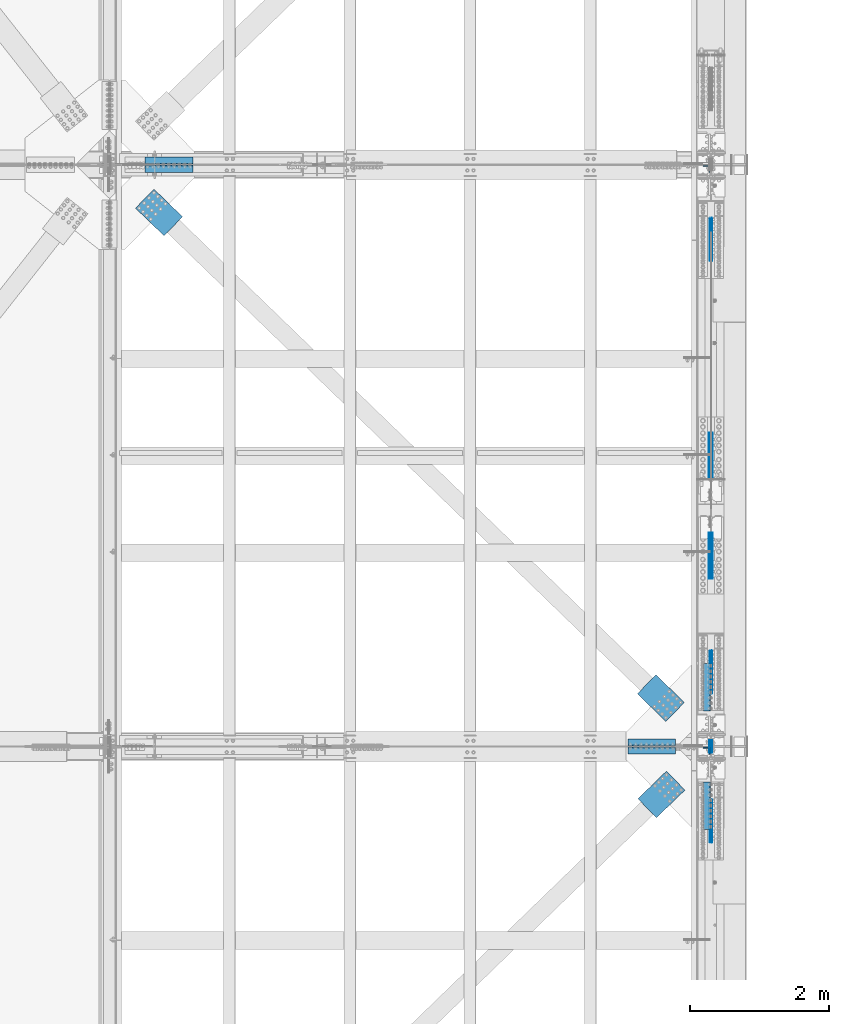
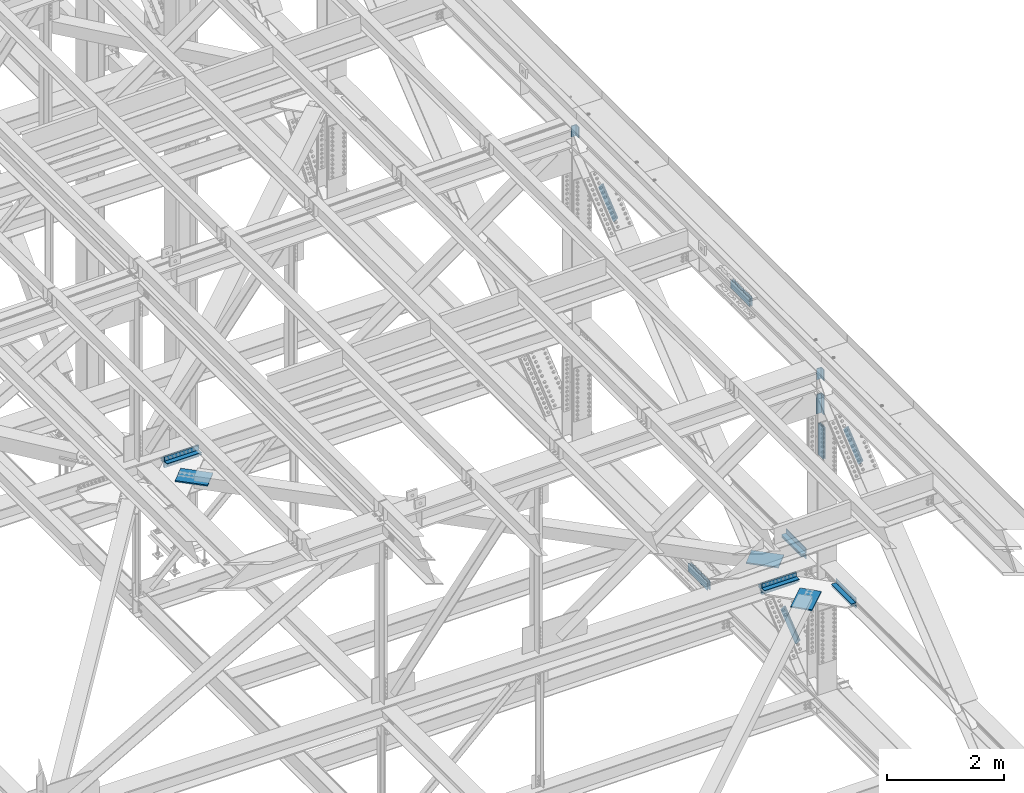
# One storey, part 2773 of 3843: 24 beams, 6 members, 11 elements without a shape of their own.
"""IFC2X3 building model written with IfcOpenShell, lengths in millimetres."""

from ifc_helpers import new_model, si_unit, frame, origin_with_axes, place, context, subcontext, project, spatial, faceted_brep, material, type_object, element, aggregate, save


model = new_model("IFC2X3")

# Units and contexts
model_context = context("Model", 3, precision=1e-05, world=origin_with_axes())
body_context = subcontext(model_context, "Body", "Model", "MODEL_VIEW")
ifc_project = project(units=[si_unit("LENGTHUNIT", "METRE", prefix="MILLI"), si_unit("AREAUNIT", "SQUARE_METRE"), si_unit("VOLUMEUNIT", "CUBIC_METRE"), si_unit("MASSUNIT", "GRAM", prefix="KILO"), si_unit("TIMEUNIT", "SECOND"), si_unit("PLANEANGLEUNIT", "RADIAN"), si_unit("SOLIDANGLEUNIT", "STERADIAN"), si_unit("THERMODYNAMICTEMPERATUREUNIT", "DEGREE_CELSIUS"), si_unit("LUMINOUSINTENSITYUNIT", "LUMEN")], contexts=[model_context])

# Site, building, storey
site_placement = place(None, origin_with_axes())
site = spatial("IfcSite", under=ifc_project, at=site_placement, CompositionType="ELEMENT")
building_placement = place(site_placement, origin_with_axes())
building = spatial("IfcBuilding", under=site, at=building_placement, Name="Undefined", CompositionType="ELEMENT")
storey_placement = place(building_placement, origin_with_axes())
storey = spatial("IfcBuildingStorey", under=building, at=storey_placement, Name="Undefined", CompositionType="ELEMENT", Elevation=0.0)

# Assembly, beam
assembly_1_placement = place(storey_placement, origin_with_axes())
assembly_1 = element("IfcElementAssembly", 1, at=assembly_1_placement, inside=storey, Name="PLATE", AssemblyPlace="NOTDEFINED", PredefinedType="RIGID_FRAME")
ifc_material = material(Name="STEEL/A572-50")
beam_type_1 = type_object("IfcBeamType", Name="L4X4X1/2", PredefinedType="NOTDEFINED")
beam_1_placement = place(assembly_1_placement, frame((78206.5999999972, 75686.4437500115, 42167.175), z_axis=(0.0, 1.0, 0.0), x_axis=(-1.0, 0.0, 0.0)))
beam_1 = element("IfcBeam", 2, at=beam_1_placement, type_object=beam_type_1, material=ifc_material, Name="ANGLE", ObjectType="L4X4X1/2", context=body_context, shape_type="Brep", body=[
    faceted_brep([(0.0, 50.8000000000029, -50.8000000000029), (0.0, 50.8000000000029, 50.8000000000029), (685.800000000003, 50.8000000000029, 50.8000000000029), (685.800000000003, 50.8000000000029, -50.8000000000029), (0.0, 38.0999999999985, 50.8000000000029), (685.800000000003, 38.0999999999985, 50.8000000000029), (0.0, 38.0999999999985, -38.0999999999985), (685.800000000003, 38.0999999999985, -38.1000000000058), (0.0, -50.8000000000029, -38.1000000000058), (685.800000000003, -50.8000000000029, -38.1000000000058), (0.0, -50.8000000000029, -50.8000000000029), (685.800000000003, -50.8000000000029, -50.8000000000029)], [[[0, 1, 2, 3]], [[1, 4, 5, 2]], [[4, 6, 7, 5]], [[6, 8, 9, 7]], [[8, 10, 11, 9]], [[10, 0, 3, 11]], [[5, 7, 9, 11, 3, 2]], [[10, 8, 6, 4, 1, 0]]]),
])

assembly_2_placement = place(storey_placement, origin_with_axes())
assembly_2 = element("IfcElementAssembly", 3, at=assembly_2_placement, inside=storey, Name="PLATE", AssemblyPlace="NOTDEFINED", PredefinedType="RIGID_FRAME")
beam_2_placement = place(assembly_2_placement, frame((77520.7999999947, 75570.5562499935, 42167.1761273977), z_axis=(0.0, -1.0, 0.0), x_axis=(1.0, 0.0, 0.0)))
beam_2 = element("IfcBeam", 4, at=beam_2_placement, type_object=beam_type_1, material=ifc_material, Name="ANGLE", ObjectType="L4X4X1/2", context=body_context, shape_type="Brep", body=[
    faceted_brep([(0.0, 50.8000000000029, -50.8000000000029), (0.0, 50.8000000000029, 50.8000000000029), (685.800000000003, 50.8000000000029, 50.8000000000029), (685.800000000003, 50.8000000000029, -50.8000000000029), (0.0, 38.0999999999985, 50.8000000000029), (685.800000000003, 38.0999999999985, 50.8000000000029), (0.0, 38.0999999999985, -38.0999999999985), (685.800000000003, 38.0999999999985, -38.1000000000058), (0.0, -50.8000000000029, -38.1000000000058), (685.800000000003, -50.8000000000029, -38.1000000000058), (0.0, -50.8000000000029, -50.8000000000029), (685.800000000003, -50.8000000000029, -50.8000000000029)], [[[0, 1, 2, 3]], [[1, 4, 5, 2]], [[4, 6, 7, 5]], [[6, 8, 9, 7]], [[8, 10, 11, 9]], [[10, 0, 3, 11]], [[5, 7, 9, 11, 3, 2]], [[10, 8, 6, 4, 1, 0]]]),
])

assembly_3_placement = place(storey_placement, origin_with_axes())
assembly_3 = element("IfcElementAssembly", 5, at=assembly_3_placement, inside=storey, Name="PLATE", AssemblyPlace="NOTDEFINED", PredefinedType="RIGID_FRAME")
beam_3_placement = place(assembly_3_placement, frame((85140.7999999975, 67329.8439999798, 42167.1749999829), z_axis=(0.0, 1.0, 0.0), x_axis=(-1.0, 0.0, 0.0)))
beam_3 = element("IfcBeam", 6, at=beam_3_placement, type_object=beam_type_1, material=ifc_material, Name="ANGLE", ObjectType="L4X4X1/2", context=body_context, shape_type="Brep", body=[
    faceted_brep([(0.0, 50.8000000000029, -50.8000000000029), (0.0, 50.8000000000029, 50.8000000000029), (685.800000000003, 50.8000000000029, 50.8000000000029), (685.800000000003, 50.8000000000029, -50.8000000000029), (0.0, 38.0999999999985, 50.8000000000029), (685.800000000003, 38.0999999999985, 50.8000000000029), (0.0, 38.0999999999985, -38.0999999999985), (685.800000000003, 38.0999999999985, -38.1000000000058), (0.0, -50.8000000000029, -38.1000000000058), (685.800000000003, -50.8000000000029, -38.1000000000058), (0.0, -50.8000000000029, -50.8000000000029), (685.800000000003, -50.8000000000029, -50.8000000000029)], [[[0, 1, 2, 3]], [[1, 4, 5, 2]], [[4, 6, 7, 5]], [[6, 8, 9, 7]], [[8, 10, 11, 9]], [[10, 0, 3, 11]], [[5, 7, 9, 11, 3, 2]], [[10, 8, 6, 4, 1, 0]]]),
])

assembly_4_placement = place(storey_placement, origin_with_axes())
assembly_4 = element("IfcElementAssembly", 7, at=assembly_4_placement, inside=storey, Name="PLATE", AssemblyPlace="NOTDEFINED", PredefinedType="RIGID_FRAME")
beam_4_placement = place(assembly_4_placement, frame((84455.0, 67213.9562499954, 42167.1744994975), z_axis=(0.0, -1.0, 0.0), x_axis=(1.0, 0.0, 0.0)))
beam_4 = element("IfcBeam", 8, at=beam_4_placement, type_object=beam_type_1, material=ifc_material, Name="ANGLE", ObjectType="L4X4X1/2", context=body_context, shape_type="Brep", body=[
    faceted_brep([(0.0, 50.8000000000029, -50.8000000000029), (0.0, 50.8000000000029, 50.8000000000029), (685.800000000003, 50.8000000000029, 50.8000000000029), (685.800000000003, 50.8000000000029, -50.8000000000029), (0.0, 38.0999999999985, 50.8000000000029), (685.800000000003, 38.0999999999985, 50.8000000000029), (0.0, 38.0999999999985, -38.0999999999985), (685.800000000003, 38.0999999999985, -38.1000000000058), (0.0, -50.8000000000029, -38.1000000000058), (685.800000000003, -50.8000000000029, -38.1000000000058), (0.0, -50.8000000000029, -50.8000000000029), (685.800000000003, -50.8000000000029, -50.8000000000029)], [[[0, 1, 2, 3]], [[1, 4, 5, 2]], [[4, 6, 7, 5]], [[6, 8, 9, 7]], [[8, 10, 11, 9]], [[10, 0, 3, 11]], [[5, 7, 9, 11, 3, 2]], [[10, 8, 6, 4, 1, 0]]]),
])

# Beam
beam_5_placement = place(assembly_3_placement, frame((84455.0000000009, 67329.8437499798, 42297.3495002585), z_axis=(0.0, 1.0, 0.0), x_axis=(1.0, 0.0, 0.0)))
beam_5 = element("IfcBeam", 9, at=beam_5_placement, type_object=beam_type_1, material=ifc_material, Name="ANGLE", ObjectType="L4X4X1/2", context=body_context, shape_type="Brep", body=[
    faceted_brep([(0.0, 50.8000000000029, -50.8000000000029), (0.0, 50.8000000000029, 50.8000000000029), (685.800000000003, 50.8000000000029, 50.8000000000029), (685.800000000003, 50.8000000000029, -50.8000000000029), (0.0, 38.0999999999985, 50.8000000000029), (685.800000000003, 38.0999999999985, 50.8000000000029), (0.0, 38.0999999999985, -38.0999999999985), (685.800000000003, 38.0999999999985, -38.1000000000058), (0.0, -50.8000000000029, -38.1000000000058), (685.800000000003, -50.8000000000029, -38.1000000000058), (0.0, -50.8000000000029, -50.8000000000029), (685.800000000003, -50.8000000000029, -50.8000000000029)], [[[0, 1, 2, 3]], [[1, 4, 5, 2]], [[4, 6, 7, 5]], [[6, 8, 9, 7]], [[8, 10, 11, 9]], [[10, 0, 3, 11]], [[5, 7, 9, 11, 3, 2]], [[10, 8, 6, 4, 1, 0]]]),
])

beam_6_placement = place(assembly_4_placement, frame((85140.8000000035, 67213.9562500019, 42297.3495002585), z_axis=(0.0, -1.0, 0.0), x_axis=(-1.0, 0.0, 0.0)))
beam_6 = element("IfcBeam", 10, at=beam_6_placement, type_object=beam_type_1, material=ifc_material, Name="ANGLE", ObjectType="L4X4X1/2", context=body_context, shape_type="Brep", body=[
    faceted_brep([(0.0, 50.8000000000029, -50.8000000000029), (0.0, 50.8000000000029, 50.8000000000029), (685.800000000003, 50.8000000000029, 50.8000000000029), (685.800000000003, 50.8000000000029, -50.8000000000029), (0.0, 38.0999999999985, 50.8000000000029), (685.800000000003, 38.0999999999985, 50.8000000000029), (0.0, 38.0999999999985, -38.0999999999985), (685.800000000003, 38.0999999999985, -38.1000000000058), (0.0, -50.8000000000029, -38.1000000000058), (685.800000000003, -50.8000000000029, -38.1000000000058), (0.0, -50.8000000000029, -50.8000000000029), (685.800000000003, -50.8000000000029, -50.8000000000029)], [[[0, 1, 2, 3]], [[1, 4, 5, 2]], [[4, 6, 7, 5]], [[6, 8, 9, 7]], [[8, 10, 11, 9]], [[10, 0, 3, 11]], [[5, 7, 9, 11, 3, 2]], [[10, 8, 6, 4, 1, 0]]]),
])

beam_7_placement = place(assembly_3_placement, frame((85591.6500000763, 67779.8999999992, 42297.3495002747), z_axis=(-1.0, 0.0, 0.0), x_axis=(0.0, 1.0, 0.0)))
beam_7 = element("IfcBeam", 11, at=beam_7_placement, type_object=beam_type_1, material=ifc_material, Name="ANGLE", ObjectType="L4X4X1/2", context=body_context, shape_type="Brep", body=[
    faceted_brep([(0.0, 50.8000000000029, -50.8000000000029), (0.0, 50.8000000000029, 50.8000000000029), (685.800000000003, 50.8000000000029, 50.8000000000029), (685.800000000003, 50.8000000000029, -50.8000000000029), (0.0, 38.0999999999985, 50.8000000000029), (685.800000000003, 38.0999999999985, 50.8000000000029), (0.0, 38.0999999999985, -38.0999999999985), (685.800000000003, 38.0999999999985, -38.1000000000058), (0.0, -50.8000000000029, -38.1000000000058), (685.800000000003, -50.8000000000029, -38.1000000000058), (0.0, -50.8000000000029, -50.8000000000029), (685.800000000003, -50.8000000000029, -50.8000000000029)], [[[0, 1, 2, 3]], [[1, 4, 5, 2]], [[4, 6, 7, 5]], [[6, 8, 9, 7]], [[8, 10, 11, 9]], [[10, 0, 3, 11]], [[5, 7, 9, 11, 3, 2]], [[10, 8, 6, 4, 1, 0]]]),
])

beam_8_placement = place(assembly_4_placement, frame((85591.6500000136, 66078.1, 42297.3495002585), z_axis=(-1.0, 0.0, 0.0), x_axis=(0.0, 1.0, 0.0)))
beam_8 = element("IfcBeam", 12, at=beam_8_placement, type_object=beam_type_1, material=ifc_material, Name="ANGLE", ObjectType="L4X4X1/2", context=body_context, shape_type="Brep", body=[
    faceted_brep([(0.0, 50.8000000000029, -50.8000000000029), (0.0, 50.8000000000029, 50.8000000000029), (685.800000000003, 50.8000000000029, 50.8000000000029), (685.800000000003, 50.8000000000029, -50.8000000000029), (0.0, 38.0999999999985, 50.8000000000029), (685.800000000003, 38.0999999999985, 50.8000000000029), (0.0, 38.0999999999985, -38.0999999999985), (685.800000000003, 38.0999999999985, -38.1000000000058), (0.0, -50.8000000000029, -38.1000000000058), (685.800000000003, -50.8000000000029, -38.1000000000058), (0.0, -50.8000000000029, -50.8000000000029), (685.800000000003, -50.8000000000029, -50.8000000000029)], [[[0, 1, 2, 3]], [[1, 4, 5, 2]], [[4, 6, 7, 5]], [[6, 8, 9, 7]], [[8, 10, 11, 9]], [[10, 0, 3, 11]], [[5, 7, 9, 11, 3, 2]], [[10, 8, 6, 4, 1, 0]]]),
])

beam_9_placement = place(assembly_2_placement, frame((78206.599999999, 75570.55625, 42297.3511281587), z_axis=(0.0, -1.0, 0.0), x_axis=(-1.0, 0.0, 0.0)))
beam_9 = element("IfcBeam", 13, at=beam_9_placement, type_object=beam_type_1, material=ifc_material, Name="ANGLE", ObjectType="L4X4X1/2", context=body_context, shape_type="Brep", body=[
    faceted_brep([(0.0, 50.8000000000029, -50.8000000000029), (0.0, 50.8000000000029, 50.8000000000029), (685.800000000003, 50.8000000000029, 50.8000000000029), (685.800000000003, 50.8000000000029, -50.8000000000029), (0.0, 38.0999999999985, 50.8000000000029), (685.800000000003, 38.0999999999985, 50.8000000000029), (0.0, 38.0999999999985, -38.0999999999985), (685.800000000003, 38.0999999999985, -38.1000000000058), (0.0, -50.8000000000029, -38.1000000000058), (685.800000000003, -50.8000000000029, -38.1000000000058), (0.0, -50.8000000000029, -50.8000000000029), (685.800000000003, -50.8000000000029, -50.8000000000029)], [[[0, 1, 2, 3]], [[1, 4, 5, 2]], [[4, 6, 7, 5]], [[6, 8, 9, 7]], [[8, 10, 11, 9]], [[10, 0, 3, 11]], [[5, 7, 9, 11, 3, 2]], [[10, 8, 6, 4, 1, 0]]]),
])

aggregate(assembly_2, [beam_2, beam_9])

beam_10_placement = place(assembly_1_placement, frame((77520.799999999, 75686.44375, 42297.350000761), z_axis=(0.0, 1.0, 0.0), x_axis=(1.0, 0.0, 0.0)))
beam_10 = element("IfcBeam", 14, at=beam_10_placement, type_object=beam_type_1, material=ifc_material, Name="ANGLE", ObjectType="L4X4X1/2", context=body_context, shape_type="Brep", body=[
    faceted_brep([(0.0, 50.8000000000029, -50.8000000000029), (0.0, 50.8000000000029, 50.8000000000029), (685.800000000003, 50.8000000000029, 50.8000000000029), (685.800000000003, 50.8000000000029, -50.8000000000029), (0.0, 38.0999999999985, 50.8000000000029), (685.800000000003, 38.0999999999985, 50.8000000000029), (0.0, 38.0999999999985, -38.0999999999985), (685.800000000003, 38.0999999999985, -38.1000000000058), (0.0, -50.8000000000029, -38.1000000000058), (685.800000000003, -50.8000000000029, -38.1000000000058), (0.0, -50.8000000000029, -50.8000000000029), (685.800000000003, -50.8000000000029, -50.8000000000029)], [[[0, 1, 2, 3]], [[1, 4, 5, 2]], [[4, 6, 7, 5]], [[6, 8, 9, 7]], [[8, 10, 11, 9]], [[10, 0, 3, 11]], [[5, 7, 9, 11, 3, 2]], [[10, 8, 6, 4, 1, 0]]]),
])

aggregate(assembly_1, [beam_1, beam_10])

beam_type_2 = type_object("IfcBeamType", Name="L4X3-1/2X1/2", PredefinedType="NOTDEFINED")
beam_11_placement = place(assembly_3_placement, frame((85591.6500000774, 68465.6999999932, 42173.5244979842), z_axis=(-1.0, 0.0, 0.0), x_axis=(0.0, -1.0, 0.0)))
beam_11 = element("IfcBeam", 15, at=beam_11_placement, type_object=beam_type_2, material=ifc_material, Name="ANGLE", ObjectType="L4X3-1/2X1/2", context=body_context, shape_type="Brep", body=[
    faceted_brep([(0.0, 44.4499999999971, -50.8000000000029), (0.0, 44.4499999999971, 50.8000000000029), (685.800000000003, 44.4499999999971, 50.8000000000029), (685.800000000003, 44.4499999999971, -50.8000000000029), (0.0, 31.75, 50.8000000000029), (685.800000000003, 31.75, 50.8000000000029), (0.0, 31.7500000838336, -38.0999999999985), (685.800000000003, 31.75, -38.0999999999985), (4.36557456851006e-11, -44.4500000000226, -38.0999999999985), (685.800000000003, -44.4499999999971, -38.0999999999985), (0.0, -44.4499999999971, -50.8000000000029), (685.800000000003, -44.4499999999971, -50.8000000000029)], [[[0, 1, 2, 3]], [[1, 4, 5, 2]], [[4, 6, 7, 5]], [[6, 8, 9, 7]], [[8, 10, 11, 9]], [[10, 0, 3, 11]], [[5, 7, 9, 11, 3, 2]], [[10, 8, 6, 4, 1, 0]]]),
])

aggregate(assembly_3, [beam_11, beam_3, beam_5, beam_7])

beam_12_placement = place(assembly_4_placement, frame((85591.6500000074, 66763.8999999895, 42173.5244979681), z_axis=(-1.0, 0.0, 0.0), x_axis=(0.0, -1.0, 0.0)))
beam_12 = element("IfcBeam", 16, at=beam_12_placement, type_object=beam_type_2, material=ifc_material, Name="ANGLE", ObjectType="L4X3-1/2X1/2", context=body_context, shape_type="Brep", body=[
    faceted_brep([(0.0, 44.4499999999971, -50.8000000000029), (0.0, 44.4499999999971, 50.8000000000029), (685.800000000003, 44.4499999999971, 50.8000000000029), (685.800000000003, 44.4499999999971, -50.8000000000029), (0.0, 31.75, 50.8000000000029), (685.800000000003, 31.75, 50.8000000000029), (0.0, 31.7500000838336, -38.0999999999985), (685.800000000003, 31.75, -38.0999999999985), (4.36557456851006e-11, -44.4500000000226, -38.0999999999985), (685.800000000003, -44.4499999999971, -38.0999999999985), (0.0, -44.4499999999971, -50.8000000000029), (685.800000000003, -44.4499999999971, -50.8000000000029)], [[[0, 1, 2, 3]], [[1, 4, 5, 2]], [[4, 6, 7, 5]], [[6, 8, 9, 7]], [[8, 10, 11, 9]], [[10, 0, 3, 11]], [[5, 7, 9, 11, 3, 2]], [[10, 8, 6, 4, 1, 0]]]),
])

aggregate(assembly_4, [beam_12, beam_4, beam_6, beam_8])

# Assembly, beams
assembly_5_placement = place(storey_placement, origin_with_axes())
assembly_5 = element("IfcElementAssembly", 17, at=assembly_5_placement, inside=storey, Name="BEAM", AssemblyPlace="NOTDEFINED", PredefinedType="RIGID_FRAME")
beam_type_3 = type_object("IfcBeamType", PredefinedType="NOTDEFINED")
beam_13_placement = place(assembly_5_placement, frame((85670.23125, 71779.9637072687, 39538.7493487036), z_axis=(0.0, 0.00209444499925302, 0.999997806647667), x_axis=(0.0, -0.999997806825691, 0.00209435999962985)))
beam_13 = element("IfcBeam", 18, at=beam_13_placement, type_object=beam_type_3, material=ifc_material, Name="PLATE", context=body_context, shape_type="Brep", body=[
    faceted_brep([(1.45519152283669e-11, 6.35000000000582, -88.8999999998996), (0.0, 6.34999999999854, 88.9000015258789), (660.399999982677, 6.35000000000582, 88.8999999999651), (660.399999982707, 6.35000000000582, -88.8999999998268), (0.0, -6.34999999999854, 88.9000015258789), (660.399999982677, -6.35000000000582, 88.8999999999651), (1.45519152283669e-11, -6.35000000000582, -88.8999999998996), (660.399999982707, -6.35000000000582, -88.8999999998268)], [[[0, 1, 2, 3]], [[1, 4, 5, 2]], [[4, 6, 7, 5]], [[6, 0, 3, 7]], [[5, 7, 3, 2]], [[6, 4, 1, 0]]]),
])
beam_14_placement = place(assembly_5_placement, frame((85627.36875, 71779.9637072687, 39538.7493487036), z_axis=(0.0, 0.00209444499925302, 0.999997806647667), x_axis=(0.0, -0.999997806825691, 0.00209435999962985)))
beam_14 = element("IfcBeam", 19, at=beam_14_placement, type_object=beam_type_3, material=ifc_material, Name="PLATE", context=body_context, shape_type="Brep", body=[
    faceted_brep([(1.45519152283669e-11, 6.35000000000582, -88.8999999998996), (0.0, 6.34999999999854, 88.9000015258789), (660.399999982677, 6.35000000000582, 88.8999999999651), (660.399999982707, 6.35000000000582, -88.8999999998268), (0.0, -6.34999999999854, 88.9000015258789), (660.399999982677, -6.35000000000582, 88.8999999999651), (1.45519152283669e-11, -6.35000000000582, -88.8999999998996), (660.399999982707, -6.35000000000582, -88.8999999998268)], [[[0, 1, 2, 3]], [[1, 4, 5, 2]], [[4, 6, 7, 5]], [[6, 0, 3, 7]], [[5, 7, 3, 2]], [[6, 4, 1, 0]]]),
])

assembly_6_placement = place(storey_placement, origin_with_axes())
assembly_6 = element("IfcElementAssembly", 20, at=assembly_6_placement, inside=storey, Name="BEAM", AssemblyPlace="NOTDEFINED", PredefinedType="RIGID_FRAME")
beam_15_placement = place(assembly_6_placement, frame((85670.23125, 70344.913729563, 46313.9371433374), z_axis=(0.0, 0.00185465600022871, 0.999998280124081), x_axis=(0.0, -0.999998280124082, 0.0018546560002281)))
beam_15 = element("IfcBeam", 21, at=beam_15_placement, type_object=beam_type_3, material=ifc_material, Name="PLATE", context=body_context, shape_type="Brep", body=[
    faceted_brep([(1.45519152283669e-11, 6.35000000000582, -88.8999999998996), (0.0, 6.34999999999854, 88.9000015258789), (660.399999982677, 6.35000000000582, 88.8999999999651), (660.399999982707, 6.35000000000582, -88.8999999998268), (0.0, -6.34999999999854, 88.9000015258789), (660.399999982677, -6.35000000000582, 88.8999999999651), (1.45519152283669e-11, -6.35000000000582, -88.8999999998996), (660.399999982707, -6.35000000000582, -88.8999999998268)], [[[0, 1, 2, 3]], [[1, 4, 5, 2]], [[4, 6, 7, 5]], [[6, 0, 3, 7]], [[5, 7, 3, 2]], [[6, 4, 1, 0]]]),
])
beam_16_placement = place(assembly_6_placement, frame((85627.36875, 70344.913729563, 46313.9371433374), z_axis=(0.0, 0.00185465600022871, 0.999998280124081), x_axis=(0.0, -0.999998280124082, 0.0018546560002281)))
beam_16 = element("IfcBeam", 22, at=beam_16_placement, type_object=beam_type_3, material=ifc_material, Name="PLATE", context=body_context, shape_type="Brep", body=[
    faceted_brep([(1.45519152283669e-11, 6.35000000000582, -88.8999999998996), (0.0, 6.34999999999854, 88.9000015258789), (660.399999982677, 6.35000000000582, 88.8999999999651), (660.399999982707, 6.35000000000582, -88.8999999998268), (0.0, -6.34999999999854, 88.9000015258789), (660.399999982677, -6.35000000000582, 88.8999999999651), (1.45519152283669e-11, -6.35000000000582, -88.8999999998996), (660.399999982707, -6.35000000000582, -88.8999999998268)], [[[0, 1, 2, 3]], [[1, 4, 5, 2]], [[4, 6, 7, 5]], [[6, 0, 3, 7]], [[5, 7, 3, 2]], [[6, 4, 1, 0]]]),
])
beam_17_placement = place(assembly_6_placement, frame((85634.5125, 67271.9000000013, 45222.0459599931), z_axis=(0.0, 1.0, 0.0), x_axis=(0.0, 0.0, -1.0)))
beam_17 = element("IfcBeam", 23, at=beam_17_placement, type_object=beam_type_3, material=ifc_material, Name="PLATE", context=body_context, shape_type="Brep", body=[
    faceted_brep([(1.45519152283669e-11, 6.35000000000582, -88.8999999998996), (0.0, 6.34999999999854, 88.9000015258789), (660.399999982677, 6.35000000000582, 88.8999999999651), (660.399999982707, 6.35000000000582, -88.8999999998268), (0.0, -6.34999999999854, 88.9000015258789), (660.399999982677, -6.35000000000582, 88.8999999999651), (1.45519152283669e-11, -6.35000000000582, -88.8999999998996), (660.399999982707, -6.35000000000582, -88.8999999998268)], [[[0, 1, 2, 3]], [[1, 4, 5, 2]], [[4, 6, 7, 5]], [[6, 0, 3, 7]], [[5, 7, 3, 2]], [[6, 4, 1, 0]]]),
])
beam_18_placement = place(assembly_6_placement, frame((85663.0875, 67271.9000000013, 45222.0459599931), z_axis=(0.0, 1.0, 0.0), x_axis=(0.0, 0.0, -1.0)))
beam_18 = element("IfcBeam", 24, at=beam_18_placement, type_object=beam_type_3, material=ifc_material, Name="PLATE", context=body_context, shape_type="Brep", body=[
    faceted_brep([(1.45519152283669e-11, 6.35000000000582, -88.8999999998996), (0.0, 6.34999999999854, 88.9000015258789), (660.399999982677, 6.35000000000582, 88.8999999999651), (660.399999982707, 6.35000000000582, -88.8999999998268), (0.0, -6.34999999999854, 88.9000015258789), (660.399999982677, -6.35000000000582, 88.8999999999651), (1.45519152283669e-11, -6.35000000000582, -88.8999999998996), (660.399999982707, -6.35000000000582, -88.8999999998268)], [[[0, 1, 2, 3]], [[1, 4, 5, 2]], [[4, 6, 7, 5]], [[6, 0, 3, 7]], [[5, 7, 3, 2]], [[6, 4, 1, 0]]]),
])

# Assembly, beam
assembly_7_placement = place(storey_placement, origin_with_axes())
assembly_7 = element("IfcElementAssembly", 25, at=assembly_7_placement, inside=storey, Name="BEAM", AssemblyPlace="NOTDEFINED", PredefinedType="RIGID_FRAME")
beam_type_4 = type_object("IfcBeamType", Name="L4X4X5/8", PredefinedType="NOTDEFINED")
beam_19_placement = place(assembly_7_placement, frame((85582.9187511538, 67209.9879995522, 46446.3200956139), z_axis=(0.0, -1.0, 0.0), x_axis=(0.0, 0.0, -1.0)))
beam_19 = element("IfcBeam", 26, at=beam_19_placement, type_object=beam_type_4, material=ifc_material, Name="ANGLE", ObjectType="L4X4X5/8", context=body_context, shape_type="Brep", body=[
    faceted_brep([(0.0, 50.8000000000029, -50.8000000000029), (0.0, 50.8000000000029, 50.8000000000029), (228.600164820818, 50.8000000000029, 50.8000000000029), (228.600164820818, 50.8000000000029, -50.8000000000029), (0.0, 34.9250000000029, 50.8000000000029), (228.600164820818, 34.9250000000029, 50.8000000000029), (0.0, 34.9250000000029, -34.9250000000029), (228.600164820818, 34.9250000000029, -34.9250000000029), (0.0, -50.8000000000029, -34.9250000000029), (228.600164820818, -50.8000000000029, -34.9250000000029), (0.0, -50.8000000000029, -50.8000000000029), (228.600164820818, -50.8000000000029, -50.8000000000029)], [[[0, 1, 2, 3]], [[1, 4, 5, 2]], [[4, 6, 7, 5]], [[6, 8, 9, 7]], [[8, 10, 11, 9]], [[10, 0, 3, 11]], [[5, 7, 9, 11, 3, 2]], [[10, 8, 6, 4, 1, 0]]]),
])

assembly_8_placement = place(storey_placement, origin_with_axes())
assembly_8 = element("IfcElementAssembly", 27, at=assembly_8_placement, inside=storey, Name="BEAM", AssemblyPlace="NOTDEFINED", PredefinedType="RIGID_FRAME")
beam_20_placement = place(assembly_8_placement, frame((85582.9187492573, 75566.5879995345, 46429.5566072688), z_axis=(0.0, -1.0, 0.0), x_axis=(0.0, 0.0, -1.0)))
beam_20 = element("IfcBeam", 28, at=beam_20_placement, type_object=beam_type_4, material=ifc_material, Name="ANGLE", ObjectType="L4X4X5/8", context=body_context, shape_type="Brep", body=[
    faceted_brep([(0.0, 50.8000000000029, -50.8000000000029), (0.0, 50.8000000000029, 50.8000000000029), (228.600164820818, 50.8000000000029, 50.8000000000029), (228.600164820818, 50.8000000000029, -50.8000000000029), (0.0, 34.9250000000029, 50.8000000000029), (228.600164820818, 34.9250000000029, 50.8000000000029), (0.0, 34.9250000000029, -34.9250000000029), (228.600164820818, 34.9250000000029, -34.9250000000029), (0.0, -50.8000000000029, -34.9250000000029), (228.600164820818, -50.8000000000029, -34.9250000000029), (0.0, -50.8000000000029, -50.8000000000029), (228.600164820818, -50.8000000000029, -50.8000000000029)], [[[0, 1, 2, 3]], [[1, 4, 5, 2]], [[4, 6, 7, 5]], [[6, 8, 9, 7]], [[8, 10, 11, 9]], [[10, 0, 3, 11]], [[5, 7, 9, 11, 3, 2]], [[10, 8, 6, 4, 1, 0]]]),
])
aggregate(assembly_8, [beam_20])

# Beam
beam_21_placement = place(assembly_7_placement, frame((85590.0625000374, 67211.5750003814, 45910.1471944771), z_axis=(0.0, -1.0, 0.0), x_axis=(0.0, 0.0, -1.0)))
beam_21 = element("IfcBeam", 29, at=beam_21_placement, type_object=beam_type_4, material=ifc_material, Name="ANGLE", ObjectType="L4X4X5/8", context=body_context, shape_type="Brep", body=[
    faceted_brep([(0.0, 50.8000000000029, -50.8000000000029), (0.0, 50.8000000000029, 50.8000000000029), (406.399999999841, 50.799999998344, 50.8000000000029), (406.399999999841, 50.799999998344, -50.8000000000029), (0.0, 34.9250000000029, 50.8000000000029), (406.399999999892, 34.924999998344, 50.8000000000029), (0.0, 34.9250000000029, -34.9250000000029), (406.399999999892, 34.924999998344, -34.9250000000029), (0.0, -50.8000000000029, -34.9250000000029), (406.400000000162, -50.8000000016473, -34.9250000000029), (0.0, -50.8000000000029, -50.8000000000029), (406.400000000162, -50.8000000016473, -50.8000000000029)], [[[0, 1, 2, 3]], [[1, 4, 5, 2]], [[4, 6, 7, 5]], [[6, 8, 9, 7]], [[8, 10, 11, 9]], [[10, 0, 3, 11]], [[5, 7, 9, 11, 3, 2]], [[10, 8, 6, 4, 1, 0]]]),
])

aggregate(assembly_7, [beam_19, beam_21])

# Member
member_type = type_object("IfcMemberType", PredefinedType="NOTDEFINED")
member_1_placement = place(assembly_5_placement, frame((85636.1, 68087.814733254, 40206.0578041735), z_axis=(0.0, -0.628634438193607, 0.777700934239511), x_axis=(0.0, 0.777700934239509, 0.628634438193609)))
member_1 = element("IfcMember", 30, at=member_1_placement, type_object=member_type, material=ifc_material, Name="PLATE", context=body_context, shape_type="Brep", body=[
    faceted_brep([(1.45519152283669e-11, 6.35000000000582, -88.8999999998996), (0.0, 6.34999999999854, 88.9000015258789), (660.399999982677, 6.35000000000582, 88.8999999999651), (660.399999982707, 6.35000000000582, -88.8999999998268), (0.0, -6.34999999999854, 88.9000015258789), (660.399999982677, -6.35000000000582, 88.8999999999651), (1.45519152283669e-11, -6.35000000000582, -88.8999999998996), (660.399999982707, -6.35000000000582, -88.8999999998268)], [[[0, 1, 2, 3]], [[1, 4, 5, 2]], [[4, 6, 7, 5]], [[6, 0, 3, 7]], [[5, 7, 3, 2]], [[6, 4, 1, 0]]]),
])

member_2_placement = place(assembly_5_placement, frame((85661.5, 68087.814733254, 40206.0578041735), z_axis=(0.0, -0.628634438193607, 0.777700934239511), x_axis=(0.0, 0.777700934239509, 0.628634438193609)))
member_2 = element("IfcMember", 31, at=member_2_placement, type_object=member_type, material=ifc_material, Name="PLATE", context=body_context, shape_type="Brep", body=[
    faceted_brep([(1.45519152283669e-11, 6.35000000000582, -88.8999999998996), (0.0, 6.34999999999854, 88.9000015258789), (660.399999982677, 6.35000000000582, 88.8999999999651), (660.399999982707, 6.35000000000582, -88.8999999998268), (0.0, -6.34999999999854, 88.9000015258789), (660.399999982677, -6.35000000000582, 88.8999999999651), (1.45519152283669e-11, -6.35000000000582, -88.8999999998996), (660.399999982707, -6.35000000000582, -88.8999999998268)], [[[0, 1, 2, 3]], [[1, 4, 5, 2]], [[4, 6, 7, 5]], [[6, 0, 3, 7]], [[5, 7, 3, 2]], [[6, 4, 1, 0]]]),
])

aggregate(assembly_5, [beam_13, beam_14, member_1, member_2])

# Assembly, members
assembly_9_placement = place(storey_placement, origin_with_axes())
assembly_9 = element("IfcElementAssembly", 32, at=assembly_9_placement, inside=storey, Name="BEAM", AssemblyPlace="NOTDEFINED", PredefinedType="RIGID_FRAME")
member_3_placement = place(assembly_9_placement, frame((85661.5, 74812.8859217587, 45642.0951807882), z_axis=(0.0, -0.628634438193607, 0.777700934239511), x_axis=(0.0, -0.777700934239515, -0.628634438193602)))
member_3 = element("IfcMember", 33, at=member_3_placement, type_object=member_type, material=ifc_material, Name="PLATE", context=body_context, shape_type="Brep", body=[
    faceted_brep([(1.45519152283669e-11, 6.35000000000582, -88.8999999998996), (0.0, 6.34999999999854, 88.9000015258789), (660.399999982677, 6.35000000000582, 88.8999999999651), (660.399999982707, 6.35000000000582, -88.8999999998268), (0.0, -6.34999999999854, 88.9000015258789), (660.399999982677, -6.35000000000582, 88.8999999999651), (1.45519152283669e-11, -6.35000000000582, -88.8999999998996), (660.399999982707, -6.35000000000582, -88.8999999998268)], [[[0, 1, 2, 3]], [[1, 4, 5, 2]], [[4, 6, 7, 5]], [[6, 0, 3, 7]], [[5, 7, 3, 2]], [[6, 4, 1, 0]]]),
])
member_4_placement = place(assembly_9_placement, frame((85636.1, 74812.8859217587, 45642.0951807882), z_axis=(0.0, -0.628634438193607, 0.777700934239511), x_axis=(0.0, -0.777700934239515, -0.628634438193602)))
member_4 = element("IfcMember", 34, at=member_4_placement, type_object=member_type, material=ifc_material, Name="PLATE", context=body_context, shape_type="Brep", body=[
    faceted_brep([(1.45519152283669e-11, 6.35000000000582, -88.8999999998996), (0.0, 6.34999999999854, 88.9000015258789), (660.399999982677, 6.35000000000582, 88.8999999999651), (660.399999982707, 6.35000000000582, -88.8999999998268), (0.0, -6.34999999999854, 88.9000015258789), (660.399999982677, -6.35000000000582, 88.8999999999651), (1.45519152283669e-11, -6.35000000000582, -88.8999999998996), (660.399999982707, -6.35000000000582, -88.8999999998268)], [[[0, 1, 2, 3]], [[1, 4, 5, 2]], [[4, 6, 7, 5]], [[6, 0, 3, 7]], [[5, 7, 3, 2]], [[6, 4, 1, 0]]]),
])
aggregate(assembly_9, [member_3, member_4])

# Member
member_5_placement = place(assembly_6_placement, frame((85661.5, 66457.7506743972, 45659.6318614305), z_axis=(0.0, -0.62928248312701, 0.777176657156856), x_axis=(0.0, -0.77717665715686, -0.629282483127005)))
member_5 = element("IfcMember", 35, at=member_5_placement, type_object=member_type, material=ifc_material, Name="PLATE", context=body_context, shape_type="Brep", body=[
    faceted_brep([(1.45519152283669e-11, 6.35000000000582, -88.8999999998996), (0.0, 6.34999999999854, 88.9000015258789), (660.399999982677, 6.35000000000582, 88.8999999999651), (660.399999982707, 6.35000000000582, -88.8999999998268), (0.0, -6.34999999999854, 88.9000015258789), (660.399999982677, -6.35000000000582, 88.8999999999651), (1.45519152283669e-11, -6.35000000000582, -88.8999999998996), (660.399999982707, -6.35000000000582, -88.8999999998268)], [[[0, 1, 2, 3]], [[1, 4, 5, 2]], [[4, 6, 7, 5]], [[6, 0, 3, 7]], [[5, 7, 3, 2]], [[6, 4, 1, 0]]]),
])

member_6_placement = place(assembly_6_placement, frame((85636.1, 66457.7506743972, 45659.6318614305), z_axis=(0.0, -0.62928248312701, 0.777176657156856), x_axis=(0.0, -0.77717665715686, -0.629282483127005)))
member_6 = element("IfcMember", 36, at=member_6_placement, type_object=member_type, material=ifc_material, Name="PLATE", context=body_context, shape_type="Brep", body=[
    faceted_brep([(1.45519152283669e-11, 6.35000000000582, -88.8999999998996), (0.0, 6.34999999999854, 88.9000015258789), (660.399999982677, 6.35000000000582, 88.8999999999651), (660.399999982707, 6.35000000000582, -88.8999999998268), (0.0, -6.34999999999854, 88.9000015258789), (660.399999982677, -6.35000000000582, 88.8999999999651), (1.45519152283669e-11, -6.35000000000582, -88.8999999998996), (660.399999982707, -6.35000000000582, -88.8999999998268)], [[[0, 1, 2, 3]], [[1, 4, 5, 2]], [[4, 6, 7, 5]], [[6, 0, 3, 7]], [[5, 7, 3, 2]], [[6, 4, 1, 0]]]),
])

aggregate(assembly_6, [beam_15, beam_16, member_5, member_6, beam_17, beam_18])

# Assembly, beam
assembly_10_placement = place(storey_placement, origin_with_axes())
assembly_10 = element("IfcElementAssembly", 37, at=assembly_10_placement, inside=storey, AssemblyPlace="NOTDEFINED", PredefinedType="RIGID_FRAME")
beam_type_5 = type_object("IfcBeamType", PredefinedType="NOTDEFINED")
beam_22_placement = place(assembly_10_placement, frame((85135.4093437171, 67768.6809647412, 42259.25), z_axis=(0.695386222991622, 0.718636208991341, 0.0), x_axis=(-0.718636212924515, 0.695386218926944, 0.0)))
beam_22 = element("IfcBeam", 38, at=beam_22_placement, type_object=beam_type_5, material=ifc_material, Name="PLATE", context=body_context, shape_type="Brep", body=[
    faceted_brep([(5.85714587941766e-10, 12.6999999999971, -190.500000000349), (-6.14818418398499e-10, 12.6999999999971, 190.500000000364), (571.499999996191, 12.6999999999971, 190.49999999936), (571.499999997392, 12.6999999999971, -190.500000001353), (-6.14818418398499e-10, -12.6999999999971, 190.500000000364), (571.499999996191, -12.6999999999971, 190.49999999936), (5.85714587941766e-10, -12.6999999999971, -190.500000000349), (571.499999997392, -12.6999999999971, -190.500000001353)], [[[0, 1, 2, 3]], [[1, 4, 5, 2]], [[4, 6, 7, 5]], [[6, 0, 3, 7]], [[5, 7, 3, 2]], [[6, 4, 1, 0]]]),
])

assembly_11_placement = place(storey_placement, origin_with_axes())
assembly_11 = element("IfcElementAssembly", 39, at=assembly_11_placement, inside=storey, AssemblyPlace="NOTDEFINED", PredefinedType="RIGID_FRAME")
beam_23_placement = place(assembly_11_placement, frame((85143.2350207841, 66782.6915473911, 42259.2494994955), z_axis=(-0.695386218410519, 0.718636213424232, 0.0), x_axis=(-0.718636213424243, -0.695386218410507, 0.0)))
beam_23 = element("IfcBeam", 40, at=beam_23_placement, type_object=beam_type_5, material=ifc_material, Name="PLATE", context=body_context, shape_type="Brep", body=[
    faceted_brep([(5.85714587941766e-10, 12.6999999999971, -190.500000000349), (-6.14818418398499e-10, 12.6999999999971, 190.500000000364), (571.499999996191, 12.6999999999971, 190.49999999936), (571.499999997392, 12.6999999999971, -190.500000001353), (-6.14818418398499e-10, -12.6999999999971, 190.500000000364), (571.499999996191, -12.6999999999971, 190.49999999936), (5.85714587941766e-10, -12.6999999999971, -190.500000000349), (571.499999997392, -12.6999999999971, -190.500000001353)], [[[0, 1, 2, 3]], [[1, 4, 5, 2]], [[4, 6, 7, 5]], [[6, 0, 3, 7]], [[5, 7, 3, 2]], [[6, 4, 1, 0]]]),
])
aggregate(assembly_11, [beam_23])

# Beam
beam_24_placement = place(assembly_10_placement, frame((77516.2194614021, 75141.3676009108, 42259.2516278839), z_axis=(-0.695386218926945, -0.718636212924513, 0.0), x_axis=(0.718636212924518, -0.695386218926941, 0.0)))
beam_24 = element("IfcBeam", 41, at=beam_24_placement, type_object=beam_type_5, material=ifc_material, Name="PLATE", context=body_context, shape_type="Brep", body=[
    faceted_brep([(5.85714587941766e-10, 12.6999999999971, -190.500000000349), (-6.14818418398499e-10, 12.6999999999971, 190.500000000364), (571.499999996191, 12.6999999999971, 190.49999999936), (571.499999997392, 12.6999999999971, -190.500000001353), (-6.14818418398499e-10, -12.6999999999971, 190.500000000364), (571.499999996191, -12.6999999999971, 190.49999999936), (5.85714587941766e-10, -12.6999999999971, -190.500000000349), (571.499999997392, -12.6999999999971, -190.500000001353)], [[[0, 1, 2, 3]], [[1, 4, 5, 2]], [[4, 6, 7, 5]], [[6, 0, 3, 7]], [[5, 7, 3, 2]], [[6, 4, 1, 0]]]),
])

aggregate(assembly_10, [beam_22, beam_24])

save(model, "model.ifc")
